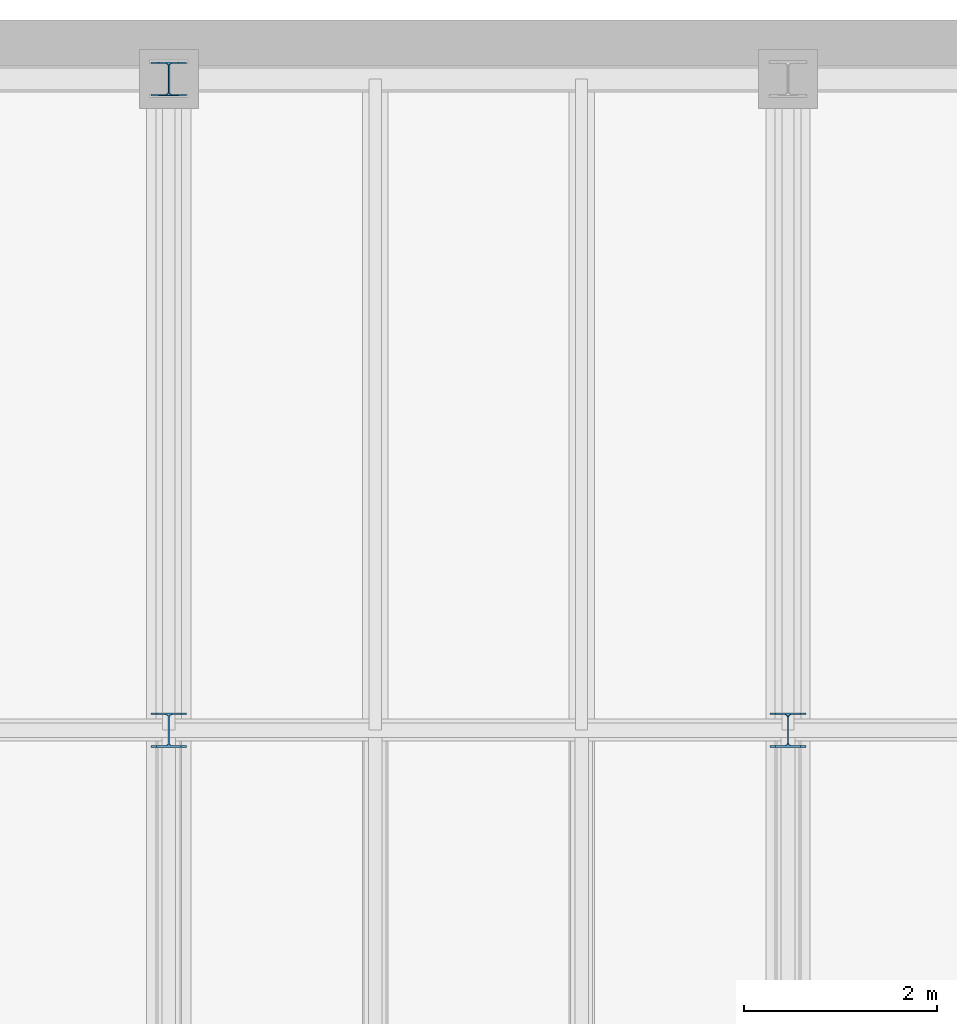
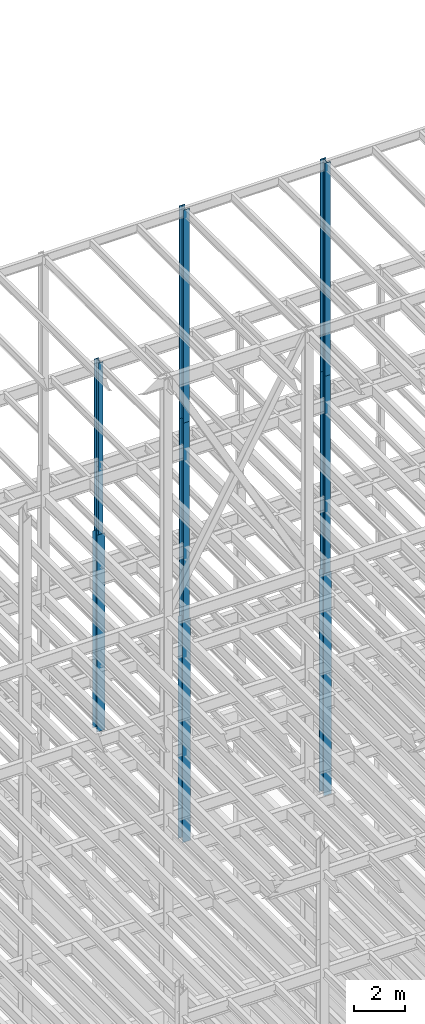
# One storey, part 62 of 150: 8 columns.
"""IFC2X3 building model written with IfcOpenShell, lengths in millimetres."""

from ifc_helpers import new_model, si_unit, frame, origin_with_axes, origin_2d_with_axis, place, context, subcontext, project, spatial, i_section, extrude, material, type_object, element, save


model = new_model("IFC2X3")

# Units and contexts
model_context = context("Model", 3, precision=1e-05, world=origin_with_axes())
body_context = subcontext(model_context, "Body", "Model", "MODEL_VIEW")
ifc_project = project(units=[si_unit("LENGTHUNIT", "METRE", prefix="MILLI"), si_unit("AREAUNIT", "SQUARE_METRE"), si_unit("VOLUMEUNIT", "CUBIC_METRE"), si_unit("MASSUNIT", "GRAM", prefix="KILO"), si_unit("TIMEUNIT", "SECOND"), si_unit("PLANEANGLEUNIT", "RADIAN"), si_unit("SOLIDANGLEUNIT", "STERADIAN"), si_unit("THERMODYNAMICTEMPERATUREUNIT", "DEGREE_CELSIUS"), si_unit("LUMINOUSINTENSITYUNIT", "LUMEN")], contexts=[model_context])

# Site, building, storey
site_placement = place(None, origin_with_axes())
site = spatial("IfcSite", under=ifc_project, at=site_placement, CompositionType="ELEMENT")
building_placement = place(site_placement, origin_with_axes())
building = spatial("IfcBuilding", under=site, at=building_placement, Name="Undefined", CompositionType="ELEMENT")
storey_placement = place(building_placement, origin_with_axes())
storey = spatial("IfcBuildingStorey", under=building, at=storey_placement, Name="Undefined", CompositionType="ELEMENT", Elevation=0.0)

# Columns
ifc_material = material(Name="STEEL/A992")
column_type_1 = type_object("IfcColumnType", Name="W14X43", PredefinedType="NOTDEFINED")
column_1_placement = place(storey_placement, frame((30988.0, 38862.0, 46253.4), z_axis=(0.0, 0.0, 1.0), x_axis=(1.0, 0.0, 0.0)))
element("IfcColumn", 1, at=column_1_placement, inside=storey, type_object=column_type_1, material=ifc_material, Name="COLUMN", ObjectType="W14X43", context=body_context, shape_type="SweptSolid", body=[
    extrude(i_section(OverallWidth=203.2, OverallDepth=346.075, WebThickness=7.9375, FlangeThickness=13.462, FilletRadius=21.4629, at=origin_2d_with_axis()), frame((0.0, 0.0, 8229.60000000002), z_axis=(0.0, 0.0, -1.0), x_axis=(-1.0, 0.0, 0.0)), (0.0, 0.0, 1.0), 8229.60000000002),
])
column_type_2 = type_object("IfcColumnType", Name="W14X90", PredefinedType="NOTDEFINED")
column_2_placement = place(storey_placement, frame((37388.8, 32131.0, 35585.4), z_axis=(0.0, 0.0, 1.0), x_axis=(1.0, 0.0, 0.0)))
element("IfcColumn", 2, at=column_2_placement, inside=storey, type_object=column_type_2, material=ifc_material, Name="COLUMN", ObjectType="W14X90", context=body_context, shape_type="SweptSolid", body=[
    extrude(i_section(OverallWidth=368.3, OverallDepth=355.6, WebThickness=11.1125, FlangeThickness=18.034, FilletRadius=32.7659, at=origin_2d_with_axis()), frame((0.0, 0.0, 10668.0009448801), z_axis=(0.0, 0.0, -1.0), x_axis=(-1.0, 0.0, 0.0)), (0.0, 0.0, 1.0), 10668.0009448801),
])
column_3_placement = place(storey_placement, frame((30988.0, 38862.0, 36804.6012877801), z_axis=(0.0, 0.0, 1.0), x_axis=(1.0, 0.0, 0.0)))
element("IfcColumn", 3, at=column_3_placement, inside=storey, type_object=column_type_2, material=ifc_material, Name="COLUMN", ObjectType="W14X90", context=body_context, shape_type="SweptSolid", body=[
    extrude(i_section(OverallWidth=368.3, OverallDepth=355.6, WebThickness=11.1125, FlangeThickness=18.034, FilletRadius=32.7659, at=origin_2d_with_axis()), frame((0.0, 0.0, 9448.79776734), z_axis=(0.0, 0.0, -1.0), x_axis=(-1.0, 0.0, 0.0)), (0.0, 0.0, 1.0), 9448.79776734),
])
column_4_placement = place(storey_placement, frame((30988.0, 32131.0, 35585.4), z_axis=(0.0, 0.0, 1.0), x_axis=(1.0, 0.0, 0.0)))
element("IfcColumn", 4, at=column_4_placement, inside=storey, type_object=column_type_2, material=ifc_material, Name="COLUMN", ObjectType="W14X90", context=body_context, shape_type="SweptSolid", body=[
    extrude(i_section(OverallWidth=368.3, OverallDepth=355.6, WebThickness=11.1125, FlangeThickness=18.034, FilletRadius=32.7659, at=origin_2d_with_axis()), frame((0.0, 0.0, 10668.0009448801), z_axis=(0.0, 0.0, -1.0), x_axis=(-1.0, 0.0, 0.0)), (0.0, 0.0, 1.0), 10668.0009448801),
])
column_type_3 = type_object("IfcColumnType", Name="W14X74", PredefinedType="NOTDEFINED")
column_5_placement = place(storey_placement, frame((37388.8, 32131.0, 55702.2), z_axis=(0.0, 0.0, 1.0), x_axis=(1.0, 0.0, 0.0)))
element("IfcColumn", 5, at=column_5_placement, inside=storey, type_object=column_type_3, material=ifc_material, Name="COLUMN", ObjectType="W14X74", context=body_context, shape_type="SweptSolid", body=[
    extrude(i_section(OverallWidth=256.54, OverallDepth=358.775, WebThickness=11.1125, FlangeThickness=19.939, FilletRadius=21.336, at=origin_2d_with_axis()), frame((0.0, 0.0, 10210.8), z_axis=(0.0, 0.0, -1.0), x_axis=(-1.0, 0.0, 0.0)), (0.0, 0.0, 1.0), 10210.8),
])
column_6_placement = place(storey_placement, frame((37388.8, 32131.0, 46253.4009448801), z_axis=(0.0, 0.0, 1.0), x_axis=(1.0, 0.0, 0.0)))
element("IfcColumn", 6, at=column_6_placement, inside=storey, type_object=column_type_3, material=ifc_material, Name="COLUMN", ObjectType="W14X74", context=body_context, shape_type="SweptSolid", body=[
    extrude(i_section(OverallWidth=256.54, OverallDepth=358.775, WebThickness=11.1125, FlangeThickness=19.939, FilletRadius=21.336, at=origin_2d_with_axis()), frame((0.0, 0.0, 9448.79811024001), z_axis=(0.0, 0.0, -1.0), x_axis=(-1.0, 0.0, 0.0)), (0.0, 0.0, 1.0), 9448.79811024001),
])
column_7_placement = place(storey_placement, frame((30988.0, 32131.0, 55702.2), z_axis=(0.0, 0.0, 1.0), x_axis=(1.0, 0.0, 0.0)))
element("IfcColumn", 7, at=column_7_placement, inside=storey, type_object=column_type_3, material=ifc_material, Name="COLUMN", ObjectType="W14X74", context=body_context, shape_type="SweptSolid", body=[
    extrude(i_section(OverallWidth=256.54, OverallDepth=358.775, WebThickness=11.1125, FlangeThickness=19.939, FilletRadius=21.336, at=origin_2d_with_axis()), frame((0.0, 0.0, 10210.8), z_axis=(0.0, 0.0, -1.0), x_axis=(-1.0, 0.0, 0.0)), (0.0, 0.0, 1.0), 10210.8),
])
column_8_placement = place(storey_placement, frame((30988.0, 32131.0, 46253.4009448801), z_axis=(0.0, 0.0, 1.0), x_axis=(1.0, 0.0, 0.0)))
element("IfcColumn", 8, at=column_8_placement, inside=storey, type_object=column_type_3, material=ifc_material, Name="COLUMN", ObjectType="W14X74", context=body_context, shape_type="SweptSolid", body=[
    extrude(i_section(OverallWidth=256.54, OverallDepth=358.775, WebThickness=11.1125, FlangeThickness=19.939, FilletRadius=21.336, at=origin_2d_with_axis()), frame((0.0, 0.0, 9448.79905511992), z_axis=(0.0, 0.0, -1.0), x_axis=(-1.0, 0.0, 0.0)), (0.0, 0.0, 1.0), 9448.7990551199),
])

save(model, "model.ifc")
